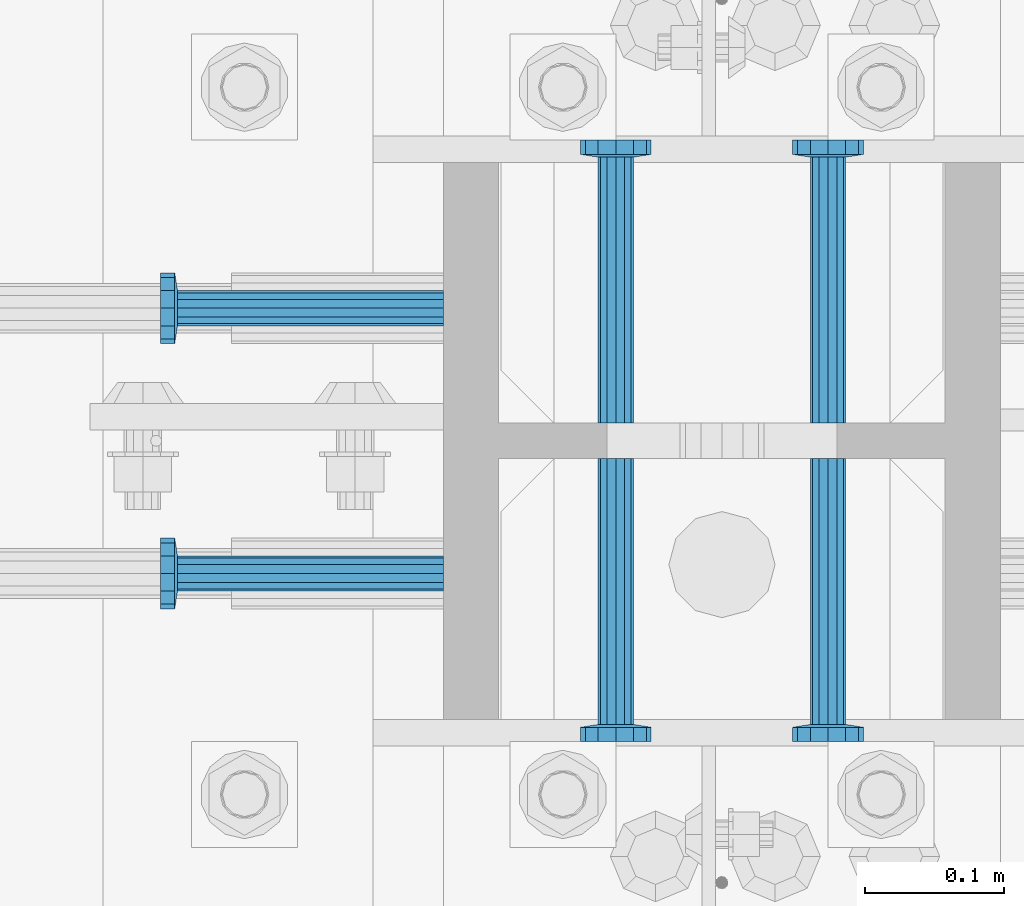
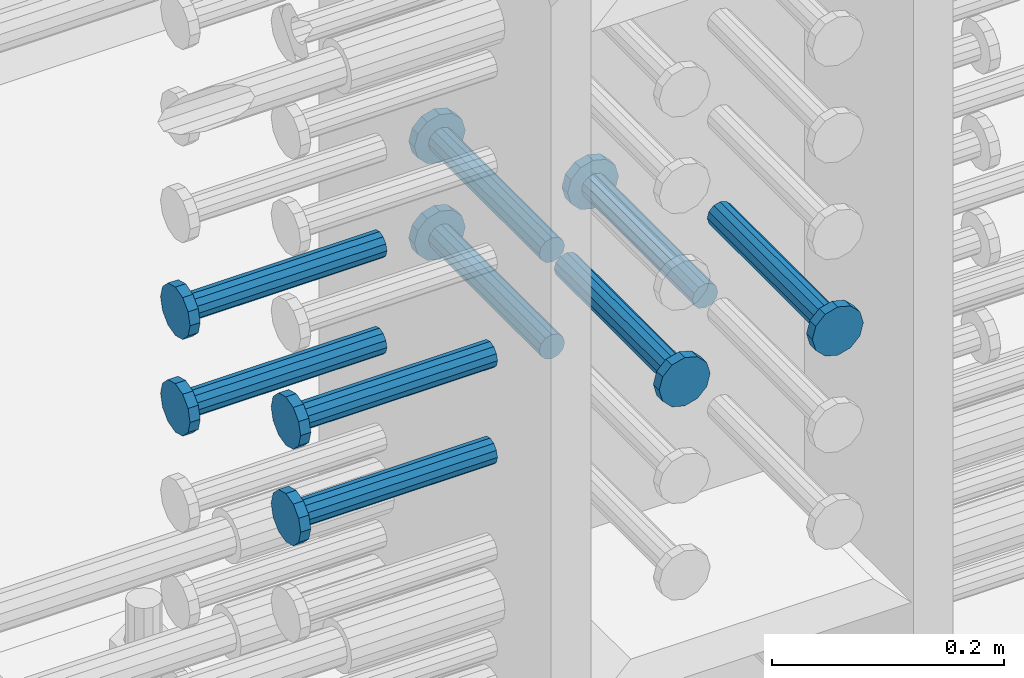
# One storey, part 1192 of 1763: 9 beams, 1 element without a shape of its own.
"""IFC2X3 building model written with IfcOpenShell, lengths in millimetres."""

from ifc_helpers import new_model, si_unit, frame, origin_with_axes, place, context, subcontext, project, spatial, faceted_brep, material, type_object, element, aggregate, save


model = new_model("IFC2X3")

# Units and contexts
model_context = context("Model", 3, precision=1e-05, world=origin_with_axes())
body_context = subcontext(model_context, "Body", "Model", "MODEL_VIEW")
ifc_project = project(units=[si_unit("LENGTHUNIT", "METRE", prefix="MILLI"), si_unit("AREAUNIT", "SQUARE_METRE"), si_unit("VOLUMEUNIT", "CUBIC_METRE"), si_unit("MASSUNIT", "GRAM", prefix="KILO"), si_unit("TIMEUNIT", "SECOND"), si_unit("PLANEANGLEUNIT", "RADIAN"), si_unit("SOLIDANGLEUNIT", "STERADIAN"), si_unit("THERMODYNAMICTEMPERATUREUNIT", "DEGREE_CELSIUS"), si_unit("LUMINOUSINTENSITYUNIT", "LUMEN")], contexts=[model_context])

# Site, building, storey
site_placement = place(None, origin_with_axes())
site = spatial("IfcSite", under=ifc_project, at=site_placement, CompositionType="ELEMENT")
building_placement = place(site_placement, origin_with_axes())
building = spatial("IfcBuilding", under=site, at=building_placement, Name="Undefined", CompositionType="ELEMENT")
storey_placement = place(building_placement, origin_with_axes())
storey = spatial("IfcBuildingStorey", under=building, at=storey_placement, Name="Undefined", CompositionType="ELEMENT", Elevation=0.0)

# Assembly, beams
assembly_placement = place(storey_placement, origin_with_axes())
assembly = element("IfcElementAssembly", 1, at=assembly_placement, inside=storey, Name="COLUMN", AssemblyPlace="NOTDEFINED", PredefinedType="RIGID_FRAME")
ifc_material = material(Name="STEEL/A108")
beam_type = type_object("IfcBeamType", PredefinedType="NOTDEFINED")
beam_1_placement = place(assembly_placement, frame((-72567.2373430988, 469.899999003702, 4419.60000000004), z_axis=(1.0, 0.0, 0.0), x_axis=(0.0, 1.0, 0.0)))
beam_1 = element("IfcBeam", 2, at=beam_1_placement, type_object=beam_type, material=ifc_material, Name="HEADED STUD ANCHOR", context=body_context, shape_type="Brep", body=[
    faceted_brep([(0.0, -12.6999999999971, -1.81898940354586e-12), (3.63797880709171e-12, -11.0, -6.34999990463257), (191.00799999576, -11.0, -6.34999990454889), (191.007999995752, -12.6999998092651, 8.36735125631094e-11), (7.27595761418343e-12, -6.34999990463257, -11.0), (191.00799999576, -6.34999990463257, -10.9999999999163), (3.63797880709171e-12, 0.0, -12.6999998092651), (191.00799999576, 0.0, -12.6999998091815), (7.27595761418343e-12, 6.34999990463257, -11.0), (191.00799999576, 6.34999990463257, -10.9999999999163), (3.63797880709171e-12, 11.0, -6.34999990463257), (191.00799999576, 11.0, -6.34999990454889), (0.0, 12.6999999999971, -1.81898940354586e-12), (191.007999995752, 12.6999998092651, 8.36735125631094e-11), (0.0, 11.0, 6.34999990463257), (191.007999995752, 11.0, 6.34999990471624), (-3.63797880709171e-12, 6.34999990463257, 11.0), (191.007999995749, 6.34999990463257, 11.0000000000837), (-3.63797880709171e-12, 0.0, 12.6999998092651), (191.007999995749, 0.0, 12.6999998093488), (-3.63797880709171e-12, -6.34999990463257, 11.0), (191.007999995749, -6.34999990463257, 11.0000000000837), (0.0, -11.0, 6.34999990463257), (191.007999995752, -11.0, 6.34999990471624), (193.039999995715, -22.0, -12.6999998091796), (193.039999995708, -25.3999996185303, 8.54925019666553e-11), (193.039999995719, -12.6999998092651, -21.9999999999145), (193.039999995719, 0.0, -25.3999996184448), (193.039999995719, 12.6999998092651, -21.9999999999145), (193.039999995715, 22.0, -12.6999998091796), (193.039999995708, 25.3999996185303, 8.54925019666553e-11), (193.039999995704, 22.0, 12.6999998093506), (193.039999995701, 12.6999998092651, 22.0000000000855), (193.039999995697, 0.0, 25.3999996186158), (193.039999995701, -12.6999998092651, 22.0000000000855), (193.039999995704, -22.0, 12.6999998093506), (203.199999995486, -22.0, -12.6999998091742), (203.199999995482, -25.3999996185303, 9.09494701772928e-11), (203.199999995493, -12.6999998092651, -21.9999999999091), (203.199999995493, 0.0, -25.3999996184393), (203.199999995493, 12.6999998092651, -21.9999999999091), (203.199999995486, 22.0, -12.6999998091742), (203.199999995482, 25.3999996185303, 9.09494701772928e-11), (203.199999995479, 22.0, 12.6999998093561), (203.199999995475, 12.6999998092651, 22.0000000000909), (203.199999995471, 0.0, 25.3999996186212), (203.199999995475, -12.6999998092651, 22.0000000000909), (203.199999995479, -22.0, 12.6999998093561)], [[[0, 1, 2, 3]], [[1, 4, 5, 2]], [[4, 6, 7, 5]], [[6, 8, 9, 7]], [[8, 10, 11, 9]], [[10, 12, 13, 11]], [[12, 14, 15, 13]], [[14, 16, 17, 15]], [[16, 18, 19, 17]], [[18, 20, 21, 19]], [[20, 22, 23, 21]], [[22, 0, 3, 23]], [[22, 20, 18, 16, 14, 12, 10, 8, 6, 4, 1, 0]], [[3, 2, 24, 25]], [[2, 5, 26, 24]], [[5, 7, 27, 26]], [[7, 9, 28, 27]], [[9, 11, 29, 28]], [[11, 13, 30, 29]], [[13, 15, 31, 30]], [[15, 17, 32, 31]], [[17, 19, 33, 32]], [[19, 21, 34, 33]], [[21, 23, 35, 34]], [[23, 3, 25, 35]], [[25, 24, 36, 37]], [[24, 26, 38, 36]], [[26, 27, 39, 38]], [[27, 28, 40, 39]], [[28, 29, 41, 40]], [[29, 30, 42, 41]], [[30, 31, 43, 42]], [[31, 32, 44, 43]], [[32, 33, 45, 44]], [[33, 34, 46, 45]], [[34, 35, 47, 46]], [[35, 25, 37, 47]], [[38, 39, 40, 41, 42, 43, 44, 45, 46, 47, 37, 36]]]),
])
beam_2_placement = place(assembly_placement, frame((-72691.0622049617, 552.45000000066, 4419.60000000004), z_axis=(0.0, 1.0, 0.0), x_axis=(-1.0, 0.0, 0.0)))
beam_2 = element("IfcBeam", 3, at=beam_2_placement, type_object=beam_type, material=ifc_material, Name="HEADED STUD ANCHOR", context=body_context, shape_type="Brep", body=[
    faceted_brep([(0.0, -12.6999999999971, -1.81898940354586e-12), (3.63797880709171e-12, -11.0, -6.34999990463257), (191.00799999576, -11.0, -6.34999990454889), (191.007999995752, -12.6999998092651, 8.36735125631094e-11), (7.27595761418343e-12, -6.34999990463257, -11.0), (191.00799999576, -6.34999990463257, -10.9999999999163), (3.63797880709171e-12, 0.0, -12.6999998092651), (191.00799999576, 0.0, -12.6999998091815), (7.27595761418343e-12, 6.34999990463257, -11.0), (191.00799999576, 6.34999990463257, -10.9999999999163), (3.63797880709171e-12, 11.0, -6.34999990463257), (191.00799999576, 11.0, -6.34999990454889), (0.0, 12.6999999999971, -1.81898940354586e-12), (191.007999995752, 12.6999998092651, 8.36735125631094e-11), (0.0, 11.0, 6.34999990463257), (191.007999995752, 11.0, 6.34999990471624), (-3.63797880709171e-12, 6.34999990463257, 11.0), (191.007999995749, 6.34999990463257, 11.0000000000837), (-3.63797880709171e-12, 0.0, 12.6999998092651), (191.007999995749, 0.0, 12.6999998093488), (-3.63797880709171e-12, -6.34999990463257, 11.0), (191.007999995749, -6.34999990463257, 11.0000000000837), (0.0, -11.0, 6.34999990463257), (191.007999995752, -11.0, 6.34999990471624), (193.039999995715, -22.0, -12.6999998091796), (193.039999995708, -25.3999996185303, 8.54925019666553e-11), (193.039999995719, -12.6999998092651, -21.9999999999145), (193.039999995719, 0.0, -25.3999996184448), (193.039999995719, 12.6999998092651, -21.9999999999145), (193.039999995715, 22.0, -12.6999998091796), (193.039999995708, 25.3999996185303, 8.54925019666553e-11), (193.039999995704, 22.0, 12.6999998093506), (193.039999995701, 12.6999998092651, 22.0000000000855), (193.039999995697, 0.0, 25.3999996186158), (193.039999995701, -12.6999998092651, 22.0000000000855), (193.039999995704, -22.0, 12.6999998093506), (203.199999995486, -22.0, -12.6999998091742), (203.199999995482, -25.3999996185303, 9.09494701772928e-11), (203.199999995493, -12.6999998092651, -21.9999999999091), (203.199999995493, 0.0, -25.3999996184393), (203.199999995493, 12.6999998092651, -21.9999999999091), (203.199999995486, 22.0, -12.6999998091742), (203.199999995482, 25.3999996185303, 9.09494701772928e-11), (203.199999995479, 22.0, 12.6999998093561), (203.199999995475, 12.6999998092651, 22.0000000000909), (203.199999995471, 0.0, 25.3999996186212), (203.199999995475, -12.6999998092651, 22.0000000000909), (203.199999995479, -22.0, 12.6999998093561)], [[[0, 1, 2, 3]], [[1, 4, 5, 2]], [[4, 6, 7, 5]], [[6, 8, 9, 7]], [[8, 10, 11, 9]], [[10, 12, 13, 11]], [[12, 14, 15, 13]], [[14, 16, 17, 15]], [[16, 18, 19, 17]], [[18, 20, 21, 19]], [[20, 22, 23, 21]], [[22, 0, 3, 23]], [[22, 20, 18, 16, 14, 12, 10, 8, 6, 4, 1, 0]], [[3, 2, 24, 25]], [[2, 5, 26, 24]], [[5, 7, 27, 26]], [[7, 9, 28, 27]], [[9, 11, 29, 28]], [[11, 13, 30, 29]], [[13, 15, 31, 30]], [[15, 17, 32, 31]], [[17, 19, 33, 32]], [[19, 21, 34, 33]], [[21, 23, 35, 34]], [[23, 3, 25, 35]], [[25, 24, 36, 37]], [[24, 26, 38, 36]], [[26, 27, 39, 38]], [[27, 28, 40, 39]], [[28, 29, 41, 40]], [[29, 30, 42, 41]], [[30, 31, 43, 42]], [[31, 32, 44, 43]], [[32, 33, 45, 44]], [[33, 34, 46, 45]], [[34, 35, 47, 46]], [[35, 25, 37, 47]], [[38, 39, 40, 41, 42, 43, 44, 45, 46, 47, 37, 36]]]),
])
beam_3_placement = place(assembly_placement, frame((-72691.0622736973, 361.950000000834, 4419.60000000004), z_axis=(0.0, 1.0, 0.0), x_axis=(-1.0, 0.0, 0.0)))
beam_3 = element("IfcBeam", 4, at=beam_3_placement, type_object=beam_type, material=ifc_material, Name="HEADED STUD ANCHOR", context=body_context, shape_type="Brep", body=[
    faceted_brep([(0.0, -12.6999999999971, -1.81898940354586e-12), (3.63797880709171e-12, -11.0, -6.34999990463257), (191.00799999576, -11.0, -6.34999990454889), (191.007999995752, -12.6999998092651, 8.36735125631094e-11), (7.27595761418343e-12, -6.34999990463257, -11.0), (191.00799999576, -6.34999990463257, -10.9999999999163), (3.63797880709171e-12, 0.0, -12.6999998092651), (191.00799999576, 0.0, -12.6999998091815), (7.27595761418343e-12, 6.34999990463257, -11.0), (191.00799999576, 6.34999990463257, -10.9999999999163), (3.63797880709171e-12, 11.0, -6.34999990463257), (191.00799999576, 11.0, -6.34999990454889), (0.0, 12.6999999999971, -1.81898940354586e-12), (191.007999995752, 12.6999998092651, 8.36735125631094e-11), (0.0, 11.0, 6.34999990463257), (191.007999995752, 11.0, 6.34999990471624), (-3.63797880709171e-12, 6.34999990463257, 11.0), (191.007999995749, 6.34999990463257, 11.0000000000837), (-3.63797880709171e-12, 0.0, 12.6999998092651), (191.007999995749, 0.0, 12.6999998093488), (-3.63797880709171e-12, -6.34999990463257, 11.0), (191.007999995749, -6.34999990463257, 11.0000000000837), (0.0, -11.0, 6.34999990463257), (191.007999995752, -11.0, 6.34999990471624), (193.039999995715, -22.0, -12.6999998091796), (193.039999995708, -25.3999996185303, 8.54925019666553e-11), (193.039999995719, -12.6999998092651, -21.9999999999145), (193.039999995719, 0.0, -25.3999996184448), (193.039999995719, 12.6999998092651, -21.9999999999145), (193.039999995715, 22.0, -12.6999998091796), (193.039999995708, 25.3999996185303, 8.54925019666553e-11), (193.039999995704, 22.0, 12.6999998093506), (193.039999995701, 12.6999998092651, 22.0000000000855), (193.039999995697, 0.0, 25.3999996186158), (193.039999995701, -12.6999998092651, 22.0000000000855), (193.039999995704, -22.0, 12.6999998093506), (203.199999995486, -22.0, -12.6999998091742), (203.199999995482, -25.3999996185303, 9.09494701772928e-11), (203.199999995493, -12.6999998092651, -21.9999999999091), (203.199999995493, 0.0, -25.3999996184393), (203.199999995493, 12.6999998092651, -21.9999999999091), (203.199999995486, 22.0, -12.6999998091742), (203.199999995482, 25.3999996185303, 9.09494701772928e-11), (203.199999995479, 22.0, 12.6999998093561), (203.199999995475, 12.6999998092651, 22.0000000000909), (203.199999995471, 0.0, 25.3999996186212), (203.199999995475, -12.6999998092651, 22.0000000000909), (203.199999995479, -22.0, 12.6999998093561)], [[[0, 1, 2, 3]], [[1, 4, 5, 2]], [[4, 6, 7, 5]], [[6, 8, 9, 7]], [[8, 10, 11, 9]], [[10, 12, 13, 11]], [[12, 14, 15, 13]], [[14, 16, 17, 15]], [[16, 18, 19, 17]], [[18, 20, 21, 19]], [[20, 22, 23, 21]], [[22, 0, 3, 23]], [[22, 20, 18, 16, 14, 12, 10, 8, 6, 4, 1, 0]], [[3, 2, 24, 25]], [[2, 5, 26, 24]], [[5, 7, 27, 26]], [[7, 9, 28, 27]], [[9, 11, 29, 28]], [[11, 13, 30, 29]], [[13, 15, 31, 30]], [[15, 17, 32, 31]], [[17, 19, 33, 32]], [[19, 21, 34, 33]], [[21, 23, 35, 34]], [[23, 3, 25, 35]], [[25, 24, 36, 37]], [[24, 26, 38, 36]], [[26, 27, 39, 38]], [[27, 28, 40, 39]], [[28, 29, 41, 40]], [[29, 30, 42, 41]], [[30, 31, 43, 42]], [[31, 32, 44, 43]], [[32, 33, 45, 44]], [[33, 34, 46, 45]], [[34, 35, 47, 46]], [[35, 25, 37, 47]], [[38, 39, 40, 41, 42, 43, 44, 45, 46, 47, 37, 36]]]),
])
beam_4_placement = place(assembly_placement, frame((-72567.2373420903, 444.499999886566, 4419.60000000004), z_axis=(1.0, 0.0, 0.0), x_axis=(0.0, -1.0, 0.0)))
beam_4 = element("IfcBeam", 5, at=beam_4_placement, type_object=beam_type, material=ifc_material, Name="HEADED STUD ANCHOR", context=body_context, shape_type="Brep", body=[
    faceted_brep([(0.0, -12.6999999999971, -1.81898940354586e-12), (3.63797880709171e-12, -11.0, -6.34999990463257), (191.00799999576, -11.0, -6.34999990454889), (191.007999995752, -12.6999998092651, 8.36735125631094e-11), (7.27595761418343e-12, -6.34999990463257, -11.0), (191.00799999576, -6.34999990463257, -10.9999999999163), (3.63797880709171e-12, 0.0, -12.6999998092651), (191.00799999576, 0.0, -12.6999998091815), (7.27595761418343e-12, 6.34999990463257, -11.0), (191.00799999576, 6.34999990463257, -10.9999999999163), (3.63797880709171e-12, 11.0, -6.34999990463257), (191.00799999576, 11.0, -6.34999990454889), (0.0, 12.6999999999971, -1.81898940354586e-12), (191.007999995752, 12.6999998092651, 8.36735125631094e-11), (0.0, 11.0, 6.34999990463257), (191.007999995752, 11.0, 6.34999990471624), (-3.63797880709171e-12, 6.34999990463257, 11.0), (191.007999995749, 6.34999990463257, 11.0000000000837), (-3.63797880709171e-12, 0.0, 12.6999998092651), (191.007999995749, 0.0, 12.6999998093488), (-3.63797880709171e-12, -6.34999990463257, 11.0), (191.007999995749, -6.34999990463257, 11.0000000000837), (0.0, -11.0, 6.34999990463257), (191.007999995752, -11.0, 6.34999990471624), (193.039999995715, -22.0, -12.6999998091796), (193.039999995708, -25.3999996185303, 8.54925019666553e-11), (193.039999995719, -12.6999998092651, -21.9999999999145), (193.039999995719, 0.0, -25.3999996184448), (193.039999995719, 12.6999998092651, -21.9999999999145), (193.039999995715, 22.0, -12.6999998091796), (193.039999995708, 25.3999996185303, 8.54925019666553e-11), (193.039999995704, 22.0, 12.6999998093506), (193.039999995701, 12.6999998092651, 22.0000000000855), (193.039999995697, 0.0, 25.3999996186158), (193.039999995701, -12.6999998092651, 22.0000000000855), (193.039999995704, -22.0, 12.6999998093506), (203.199999995486, -22.0, -12.6999998091742), (203.199999995482, -25.3999996185303, 9.09494701772928e-11), (203.199999995493, -12.6999998092651, -21.9999999999091), (203.199999995493, 0.0, -25.3999996184393), (203.199999995493, 12.6999998092651, -21.9999999999091), (203.199999995486, 22.0, -12.6999998091742), (203.199999995482, 25.3999996185303, 9.09494701772928e-11), (203.199999995479, 22.0, 12.6999998093561), (203.199999995475, 12.6999998092651, 22.0000000000909), (203.199999995471, 0.0, 25.3999996186212), (203.199999995475, -12.6999998092651, 22.0000000000909), (203.199999995479, -22.0, 12.6999998093561)], [[[0, 1, 2, 3]], [[1, 4, 5, 2]], [[4, 6, 7, 5]], [[6, 8, 9, 7]], [[8, 10, 11, 9]], [[10, 12, 13, 11]], [[12, 14, 15, 13]], [[14, 16, 17, 15]], [[16, 18, 19, 17]], [[18, 20, 21, 19]], [[20, 22, 23, 21]], [[22, 0, 3, 23]], [[22, 20, 18, 16, 14, 12, 10, 8, 6, 4, 1, 0]], [[3, 2, 24, 25]], [[2, 5, 26, 24]], [[5, 7, 27, 26]], [[7, 9, 28, 27]], [[9, 11, 29, 28]], [[11, 13, 30, 29]], [[13, 15, 31, 30]], [[15, 17, 32, 31]], [[17, 19, 33, 32]], [[19, 21, 34, 33]], [[21, 23, 35, 34]], [[23, 3, 25, 35]], [[25, 24, 36, 37]], [[24, 26, 38, 36]], [[26, 27, 39, 38]], [[27, 28, 40, 39]], [[28, 29, 41, 40]], [[29, 30, 42, 41]], [[30, 31, 43, 42]], [[31, 32, 44, 43]], [[32, 33, 45, 44]], [[33, 34, 46, 45]], [[34, 35, 47, 46]], [[35, 25, 37, 47]], [[38, 39, 40, 41, 42, 43, 44, 45, 46, 47, 37, 36]]]),
])
beam_5_placement = place(assembly_placement, frame((-72414.8373420912, 444.500000000843, 4419.60000000004), z_axis=(1.0, 0.0, 0.0), x_axis=(0.0, -1.0, 0.0)))
beam_5 = element("IfcBeam", 6, at=beam_5_placement, type_object=beam_type, material=ifc_material, Name="HEADED STUD ANCHOR", context=body_context, shape_type="Brep", body=[
    faceted_brep([(0.0, -12.6999999999971, -1.81898940354586e-12), (3.63797880709171e-12, -11.0, -6.34999990463257), (191.00799999576, -11.0, -6.34999990454889), (191.007999995752, -12.6999998092651, 8.36735125631094e-11), (7.27595761418343e-12, -6.34999990463257, -11.0), (191.00799999576, -6.34999990463257, -10.9999999999163), (3.63797880709171e-12, 0.0, -12.6999998092651), (191.00799999576, 0.0, -12.6999998091815), (7.27595761418343e-12, 6.34999990463257, -11.0), (191.00799999576, 6.34999990463257, -10.9999999999163), (3.63797880709171e-12, 11.0, -6.34999990463257), (191.00799999576, 11.0, -6.34999990454889), (0.0, 12.6999999999971, -1.81898940354586e-12), (191.007999995752, 12.6999998092651, 8.36735125631094e-11), (0.0, 11.0, 6.34999990463257), (191.007999995752, 11.0, 6.34999990471624), (-3.63797880709171e-12, 6.34999990463257, 11.0), (191.007999995749, 6.34999990463257, 11.0000000000837), (-3.63797880709171e-12, 0.0, 12.6999998092651), (191.007999995749, 0.0, 12.6999998093488), (-3.63797880709171e-12, -6.34999990463257, 11.0), (191.007999995749, -6.34999990463257, 11.0000000000837), (0.0, -11.0, 6.34999990463257), (191.007999995752, -11.0, 6.34999990471624), (193.039999995715, -22.0, -12.6999998091796), (193.039999995708, -25.3999996185303, 8.54925019666553e-11), (193.039999995719, -12.6999998092651, -21.9999999999145), (193.039999995719, 0.0, -25.3999996184448), (193.039999995719, 12.6999998092651, -21.9999999999145), (193.039999995715, 22.0, -12.6999998091796), (193.039999995708, 25.3999996185303, 8.54925019666553e-11), (193.039999995704, 22.0, 12.6999998093506), (193.039999995701, 12.6999998092651, 22.0000000000855), (193.039999995697, 0.0, 25.3999996186158), (193.039999995701, -12.6999998092651, 22.0000000000855), (193.039999995704, -22.0, 12.6999998093506), (203.199999995486, -22.0, -12.6999998091742), (203.199999995482, -25.3999996185303, 9.09494701772928e-11), (203.199999995493, -12.6999998092651, -21.9999999999091), (203.199999995493, 0.0, -25.3999996184393), (203.199999995493, 12.6999998092651, -21.9999999999091), (203.199999995486, 22.0, -12.6999998091742), (203.199999995482, 25.3999996185303, 9.09494701772928e-11), (203.199999995479, 22.0, 12.6999998093561), (203.199999995475, 12.6999998092651, 22.0000000000909), (203.199999995471, 0.0, 25.3999996186212), (203.199999995475, -12.6999998092651, 22.0000000000909), (203.199999995479, -22.0, 12.6999998093561)], [[[0, 1, 2, 3]], [[1, 4, 5, 2]], [[4, 6, 7, 5]], [[6, 8, 9, 7]], [[8, 10, 11, 9]], [[10, 12, 13, 11]], [[12, 14, 15, 13]], [[14, 16, 17, 15]], [[16, 18, 19, 17]], [[18, 20, 21, 19]], [[20, 22, 23, 21]], [[22, 0, 3, 23]], [[22, 20, 18, 16, 14, 12, 10, 8, 6, 4, 1, 0]], [[3, 2, 24, 25]], [[2, 5, 26, 24]], [[5, 7, 27, 26]], [[7, 9, 28, 27]], [[9, 11, 29, 28]], [[11, 13, 30, 29]], [[13, 15, 31, 30]], [[15, 17, 32, 31]], [[17, 19, 33, 32]], [[19, 21, 34, 33]], [[21, 23, 35, 34]], [[23, 3, 25, 35]], [[25, 24, 36, 37]], [[24, 26, 38, 36]], [[26, 27, 39, 38]], [[27, 28, 40, 39]], [[28, 29, 41, 40]], [[29, 30, 42, 41]], [[30, 31, 43, 42]], [[31, 32, 44, 43]], [[32, 33, 45, 44]], [[33, 34, 46, 45]], [[34, 35, 47, 46]], [[35, 25, 37, 47]], [[38, 39, 40, 41, 42, 43, 44, 45, 46, 47, 37, 36]]]),
])
beam_6_placement = place(assembly_placement, frame((-72414.837343099, 469.900000000843, 4318.00000000004), z_axis=(1.0, 0.0, 0.0), x_axis=(0.0, 1.0, 0.0)))
beam_6 = element("IfcBeam", 7, at=beam_6_placement, type_object=beam_type, material=ifc_material, Name="HEADED STUD ANCHOR", context=body_context, shape_type="Brep", body=[
    faceted_brep([(0.0, -12.6999999999971, -1.81898940354586e-12), (3.63797880709171e-12, -11.0, -6.34999990463257), (191.00799999576, -11.0, -6.34999990454889), (191.007999995752, -12.6999998092651, 8.36735125631094e-11), (7.27595761418343e-12, -6.34999990463257, -11.0), (191.00799999576, -6.34999990463257, -10.9999999999163), (3.63797880709171e-12, 0.0, -12.6999998092651), (191.00799999576, 0.0, -12.6999998091815), (7.27595761418343e-12, 6.34999990463257, -11.0), (191.00799999576, 6.34999990463257, -10.9999999999163), (3.63797880709171e-12, 11.0, -6.34999990463257), (191.00799999576, 11.0, -6.34999990454889), (0.0, 12.6999999999971, -1.81898940354586e-12), (191.007999995752, 12.6999998092651, 8.36735125631094e-11), (0.0, 11.0, 6.34999990463257), (191.007999995752, 11.0, 6.34999990471624), (-3.63797880709171e-12, 6.34999990463257, 11.0), (191.007999995749, 6.34999990463257, 11.0000000000837), (-3.63797880709171e-12, 0.0, 12.6999998092651), (191.007999995749, 0.0, 12.6999998093488), (-3.63797880709171e-12, -6.34999990463257, 11.0), (191.007999995749, -6.34999990463257, 11.0000000000837), (0.0, -11.0, 6.34999990463257), (191.007999995752, -11.0, 6.34999990471624), (193.039999995715, -22.0, -12.6999998091796), (193.039999995708, -25.3999996185303, 8.54925019666553e-11), (193.039999995719, -12.6999998092651, -21.9999999999145), (193.039999995719, 0.0, -25.3999996184448), (193.039999995719, 12.6999998092651, -21.9999999999145), (193.039999995715, 22.0, -12.6999998091796), (193.039999995708, 25.3999996185303, 8.54925019666553e-11), (193.039999995704, 22.0, 12.6999998093506), (193.039999995701, 12.6999998092651, 22.0000000000855), (193.039999995697, 0.0, 25.3999996186158), (193.039999995701, -12.6999998092651, 22.0000000000855), (193.039999995704, -22.0, 12.6999998093506), (203.199999995486, -22.0, -12.6999998091742), (203.199999995482, -25.3999996185303, 9.09494701772928e-11), (203.199999995493, -12.6999998092651, -21.9999999999091), (203.199999995493, 0.0, -25.3999996184393), (203.199999995493, 12.6999998092651, -21.9999999999091), (203.199999995486, 22.0, -12.6999998091742), (203.199999995482, 25.3999996185303, 9.09494701772928e-11), (203.199999995479, 22.0, 12.6999998093561), (203.199999995475, 12.6999998092651, 22.0000000000909), (203.199999995471, 0.0, 25.3999996186212), (203.199999995475, -12.6999998092651, 22.0000000000909), (203.199999995479, -22.0, 12.6999998093561)], [[[0, 1, 2, 3]], [[1, 4, 5, 2]], [[4, 6, 7, 5]], [[6, 8, 9, 7]], [[8, 10, 11, 9]], [[10, 12, 13, 11]], [[12, 14, 15, 13]], [[14, 16, 17, 15]], [[16, 18, 19, 17]], [[18, 20, 21, 19]], [[20, 22, 23, 21]], [[22, 0, 3, 23]], [[22, 20, 18, 16, 14, 12, 10, 8, 6, 4, 1, 0]], [[3, 2, 24, 25]], [[2, 5, 26, 24]], [[5, 7, 27, 26]], [[7, 9, 28, 27]], [[9, 11, 29, 28]], [[11, 13, 30, 29]], [[13, 15, 31, 30]], [[15, 17, 32, 31]], [[17, 19, 33, 32]], [[19, 21, 34, 33]], [[21, 23, 35, 34]], [[23, 3, 25, 35]], [[25, 24, 36, 37]], [[24, 26, 38, 36]], [[26, 27, 39, 38]], [[27, 28, 40, 39]], [[28, 29, 41, 40]], [[29, 30, 42, 41]], [[30, 31, 43, 42]], [[31, 32, 44, 43]], [[32, 33, 45, 44]], [[33, 34, 46, 45]], [[34, 35, 47, 46]], [[35, 25, 37, 47]], [[38, 39, 40, 41, 42, 43, 44, 45, 46, 47, 37, 36]]]),
])
beam_7_placement = place(assembly_placement, frame((-72567.2373430988, 469.899999003702, 4318.00000000004), z_axis=(1.0, 0.0, 0.0), x_axis=(0.0, 1.0, 0.0)))
beam_7 = element("IfcBeam", 8, at=beam_7_placement, type_object=beam_type, material=ifc_material, Name="HEADED STUD ANCHOR", context=body_context, shape_type="Brep", body=[
    faceted_brep([(0.0, -12.6999999999971, -1.81898940354586e-12), (3.63797880709171e-12, -11.0, -6.34999990463257), (191.00799999576, -11.0, -6.34999990454889), (191.007999995752, -12.6999998092651, 8.36735125631094e-11), (7.27595761418343e-12, -6.34999990463257, -11.0), (191.00799999576, -6.34999990463257, -10.9999999999163), (3.63797880709171e-12, 0.0, -12.6999998092651), (191.00799999576, 0.0, -12.6999998091815), (7.27595761418343e-12, 6.34999990463257, -11.0), (191.00799999576, 6.34999990463257, -10.9999999999163), (3.63797880709171e-12, 11.0, -6.34999990463257), (191.00799999576, 11.0, -6.34999990454889), (0.0, 12.6999999999971, -1.81898940354586e-12), (191.007999995752, 12.6999998092651, 8.36735125631094e-11), (0.0, 11.0, 6.34999990463257), (191.007999995752, 11.0, 6.34999990471624), (-3.63797880709171e-12, 6.34999990463257, 11.0), (191.007999995749, 6.34999990463257, 11.0000000000837), (-3.63797880709171e-12, 0.0, 12.6999998092651), (191.007999995749, 0.0, 12.6999998093488), (-3.63797880709171e-12, -6.34999990463257, 11.0), (191.007999995749, -6.34999990463257, 11.0000000000837), (0.0, -11.0, 6.34999990463257), (191.007999995752, -11.0, 6.34999990471624), (193.039999995715, -22.0, -12.6999998091796), (193.039999995708, -25.3999996185303, 8.54925019666553e-11), (193.039999995719, -12.6999998092651, -21.9999999999145), (193.039999995719, 0.0, -25.3999996184448), (193.039999995719, 12.6999998092651, -21.9999999999145), (193.039999995715, 22.0, -12.6999998091796), (193.039999995708, 25.3999996185303, 8.54925019666553e-11), (193.039999995704, 22.0, 12.6999998093506), (193.039999995701, 12.6999998092651, 22.0000000000855), (193.039999995697, 0.0, 25.3999996186158), (193.039999995701, -12.6999998092651, 22.0000000000855), (193.039999995704, -22.0, 12.6999998093506), (203.199999995486, -22.0, -12.6999998091742), (203.199999995482, -25.3999996185303, 9.09494701772928e-11), (203.199999995493, -12.6999998092651, -21.9999999999091), (203.199999995493, 0.0, -25.3999996184393), (203.199999995493, 12.6999998092651, -21.9999999999091), (203.199999995486, 22.0, -12.6999998091742), (203.199999995482, 25.3999996185303, 9.09494701772928e-11), (203.199999995479, 22.0, 12.6999998093561), (203.199999995475, 12.6999998092651, 22.0000000000909), (203.199999995471, 0.0, 25.3999996186212), (203.199999995475, -12.6999998092651, 22.0000000000909), (203.199999995479, -22.0, 12.6999998093561)], [[[0, 1, 2, 3]], [[1, 4, 5, 2]], [[4, 6, 7, 5]], [[6, 8, 9, 7]], [[8, 10, 11, 9]], [[10, 12, 13, 11]], [[12, 14, 15, 13]], [[14, 16, 17, 15]], [[16, 18, 19, 17]], [[18, 20, 21, 19]], [[20, 22, 23, 21]], [[22, 0, 3, 23]], [[22, 20, 18, 16, 14, 12, 10, 8, 6, 4, 1, 0]], [[3, 2, 24, 25]], [[2, 5, 26, 24]], [[5, 7, 27, 26]], [[7, 9, 28, 27]], [[9, 11, 29, 28]], [[11, 13, 30, 29]], [[13, 15, 31, 30]], [[15, 17, 32, 31]], [[17, 19, 33, 32]], [[19, 21, 34, 33]], [[21, 23, 35, 34]], [[23, 3, 25, 35]], [[25, 24, 36, 37]], [[24, 26, 38, 36]], [[26, 27, 39, 38]], [[27, 28, 40, 39]], [[28, 29, 41, 40]], [[29, 30, 42, 41]], [[30, 31, 43, 42]], [[31, 32, 44, 43]], [[32, 33, 45, 44]], [[33, 34, 46, 45]], [[34, 35, 47, 46]], [[35, 25, 37, 47]], [[38, 39, 40, 41, 42, 43, 44, 45, 46, 47, 37, 36]]]),
])
beam_8_placement = place(assembly_placement, frame((-72691.0622049617, 552.45000000066, 4318.00000000004), z_axis=(0.0, 1.0, 0.0), x_axis=(-1.0, 0.0, 0.0)))
beam_8 = element("IfcBeam", 9, at=beam_8_placement, type_object=beam_type, material=ifc_material, Name="HEADED STUD ANCHOR", context=body_context, shape_type="Brep", body=[
    faceted_brep([(0.0, -12.6999999999971, -1.81898940354586e-12), (3.63797880709171e-12, -11.0, -6.34999990463257), (191.00799999576, -11.0, -6.34999990454889), (191.007999995752, -12.6999998092651, 8.36735125631094e-11), (7.27595761418343e-12, -6.34999990463257, -11.0), (191.00799999576, -6.34999990463257, -10.9999999999163), (3.63797880709171e-12, 0.0, -12.6999998092651), (191.00799999576, 0.0, -12.6999998091815), (7.27595761418343e-12, 6.34999990463257, -11.0), (191.00799999576, 6.34999990463257, -10.9999999999163), (3.63797880709171e-12, 11.0, -6.34999990463257), (191.00799999576, 11.0, -6.34999990454889), (0.0, 12.6999999999971, -1.81898940354586e-12), (191.007999995752, 12.6999998092651, 8.36735125631094e-11), (0.0, 11.0, 6.34999990463257), (191.007999995752, 11.0, 6.34999990471624), (-3.63797880709171e-12, 6.34999990463257, 11.0), (191.007999995749, 6.34999990463257, 11.0000000000837), (-3.63797880709171e-12, 0.0, 12.6999998092651), (191.007999995749, 0.0, 12.6999998093488), (-3.63797880709171e-12, -6.34999990463257, 11.0), (191.007999995749, -6.34999990463257, 11.0000000000837), (0.0, -11.0, 6.34999990463257), (191.007999995752, -11.0, 6.34999990471624), (193.039999995715, -22.0, -12.6999998091796), (193.039999995708, -25.3999996185303, 8.54925019666553e-11), (193.039999995719, -12.6999998092651, -21.9999999999145), (193.039999995719, 0.0, -25.3999996184448), (193.039999995719, 12.6999998092651, -21.9999999999145), (193.039999995715, 22.0, -12.6999998091796), (193.039999995708, 25.3999996185303, 8.54925019666553e-11), (193.039999995704, 22.0, 12.6999998093506), (193.039999995701, 12.6999998092651, 22.0000000000855), (193.039999995697, 0.0, 25.3999996186158), (193.039999995701, -12.6999998092651, 22.0000000000855), (193.039999995704, -22.0, 12.6999998093506), (203.199999995486, -22.0, -12.6999998091742), (203.199999995482, -25.3999996185303, 9.09494701772928e-11), (203.199999995493, -12.6999998092651, -21.9999999999091), (203.199999995493, 0.0, -25.3999996184393), (203.199999995493, 12.6999998092651, -21.9999999999091), (203.199999995486, 22.0, -12.6999998091742), (203.199999995482, 25.3999996185303, 9.09494701772928e-11), (203.199999995479, 22.0, 12.6999998093561), (203.199999995475, 12.6999998092651, 22.0000000000909), (203.199999995471, 0.0, 25.3999996186212), (203.199999995475, -12.6999998092651, 22.0000000000909), (203.199999995479, -22.0, 12.6999998093561)], [[[0, 1, 2, 3]], [[1, 4, 5, 2]], [[4, 6, 7, 5]], [[6, 8, 9, 7]], [[8, 10, 11, 9]], [[10, 12, 13, 11]], [[12, 14, 15, 13]], [[14, 16, 17, 15]], [[16, 18, 19, 17]], [[18, 20, 21, 19]], [[20, 22, 23, 21]], [[22, 0, 3, 23]], [[22, 20, 18, 16, 14, 12, 10, 8, 6, 4, 1, 0]], [[3, 2, 24, 25]], [[2, 5, 26, 24]], [[5, 7, 27, 26]], [[7, 9, 28, 27]], [[9, 11, 29, 28]], [[11, 13, 30, 29]], [[13, 15, 31, 30]], [[15, 17, 32, 31]], [[17, 19, 33, 32]], [[19, 21, 34, 33]], [[21, 23, 35, 34]], [[23, 3, 25, 35]], [[25, 24, 36, 37]], [[24, 26, 38, 36]], [[26, 27, 39, 38]], [[27, 28, 40, 39]], [[28, 29, 41, 40]], [[29, 30, 42, 41]], [[30, 31, 43, 42]], [[31, 32, 44, 43]], [[32, 33, 45, 44]], [[33, 34, 46, 45]], [[34, 35, 47, 46]], [[35, 25, 37, 47]], [[38, 39, 40, 41, 42, 43, 44, 45, 46, 47, 37, 36]]]),
])
beam_9_placement = place(assembly_placement, frame((-72691.0622736973, 361.950000000834, 4318.00000000004), z_axis=(0.0, 1.0, 0.0), x_axis=(-1.0, 0.0, 0.0)))
beam_9 = element("IfcBeam", 10, at=beam_9_placement, type_object=beam_type, material=ifc_material, Name="HEADED STUD ANCHOR", context=body_context, shape_type="Brep", body=[
    faceted_brep([(0.0, -12.6999999999971, -1.81898940354586e-12), (3.63797880709171e-12, -11.0, -6.34999990463257), (191.00799999576, -11.0, -6.34999990454889), (191.007999995752, -12.6999998092651, 8.36735125631094e-11), (7.27595761418343e-12, -6.34999990463257, -11.0), (191.00799999576, -6.34999990463257, -10.9999999999163), (3.63797880709171e-12, 0.0, -12.6999998092651), (191.00799999576, 0.0, -12.6999998091815), (7.27595761418343e-12, 6.34999990463257, -11.0), (191.00799999576, 6.34999990463257, -10.9999999999163), (3.63797880709171e-12, 11.0, -6.34999990463257), (191.00799999576, 11.0, -6.34999990454889), (0.0, 12.6999999999971, -1.81898940354586e-12), (191.007999995752, 12.6999998092651, 8.36735125631094e-11), (0.0, 11.0, 6.34999990463257), (191.007999995752, 11.0, 6.34999990471624), (-3.63797880709171e-12, 6.34999990463257, 11.0), (191.007999995749, 6.34999990463257, 11.0000000000837), (-3.63797880709171e-12, 0.0, 12.6999998092651), (191.007999995749, 0.0, 12.6999998093488), (-3.63797880709171e-12, -6.34999990463257, 11.0), (191.007999995749, -6.34999990463257, 11.0000000000837), (0.0, -11.0, 6.34999990463257), (191.007999995752, -11.0, 6.34999990471624), (193.039999995715, -22.0, -12.6999998091796), (193.039999995708, -25.3999996185303, 8.54925019666553e-11), (193.039999995719, -12.6999998092651, -21.9999999999145), (193.039999995719, 0.0, -25.3999996184448), (193.039999995719, 12.6999998092651, -21.9999999999145), (193.039999995715, 22.0, -12.6999998091796), (193.039999995708, 25.3999996185303, 8.54925019666553e-11), (193.039999995704, 22.0, 12.6999998093506), (193.039999995701, 12.6999998092651, 22.0000000000855), (193.039999995697, 0.0, 25.3999996186158), (193.039999995701, -12.6999998092651, 22.0000000000855), (193.039999995704, -22.0, 12.6999998093506), (203.199999995486, -22.0, -12.6999998091742), (203.199999995482, -25.3999996185303, 9.09494701772928e-11), (203.199999995493, -12.6999998092651, -21.9999999999091), (203.199999995493, 0.0, -25.3999996184393), (203.199999995493, 12.6999998092651, -21.9999999999091), (203.199999995486, 22.0, -12.6999998091742), (203.199999995482, 25.3999996185303, 9.09494701772928e-11), (203.199999995479, 22.0, 12.6999998093561), (203.199999995475, 12.6999998092651, 22.0000000000909), (203.199999995471, 0.0, 25.3999996186212), (203.199999995475, -12.6999998092651, 22.0000000000909), (203.199999995479, -22.0, 12.6999998093561)], [[[0, 1, 2, 3]], [[1, 4, 5, 2]], [[4, 6, 7, 5]], [[6, 8, 9, 7]], [[8, 10, 11, 9]], [[10, 12, 13, 11]], [[12, 14, 15, 13]], [[14, 16, 17, 15]], [[16, 18, 19, 17]], [[18, 20, 21, 19]], [[20, 22, 23, 21]], [[22, 0, 3, 23]], [[22, 20, 18, 16, 14, 12, 10, 8, 6, 4, 1, 0]], [[3, 2, 24, 25]], [[2, 5, 26, 24]], [[5, 7, 27, 26]], [[7, 9, 28, 27]], [[9, 11, 29, 28]], [[11, 13, 30, 29]], [[13, 15, 31, 30]], [[15, 17, 32, 31]], [[17, 19, 33, 32]], [[19, 21, 34, 33]], [[21, 23, 35, 34]], [[23, 3, 25, 35]], [[25, 24, 36, 37]], [[24, 26, 38, 36]], [[26, 27, 39, 38]], [[27, 28, 40, 39]], [[28, 29, 41, 40]], [[29, 30, 42, 41]], [[30, 31, 43, 42]], [[31, 32, 44, 43]], [[32, 33, 45, 44]], [[33, 34, 46, 45]], [[34, 35, 47, 46]], [[35, 25, 37, 47]], [[38, 39, 40, 41, 42, 43, 44, 45, 46, 47, 37, 36]]]),
])
aggregate(assembly, [beam_1, beam_2, beam_3, beam_4, beam_5, beam_6, beam_7, beam_8, beam_9])

save(model, "model.ifc")
